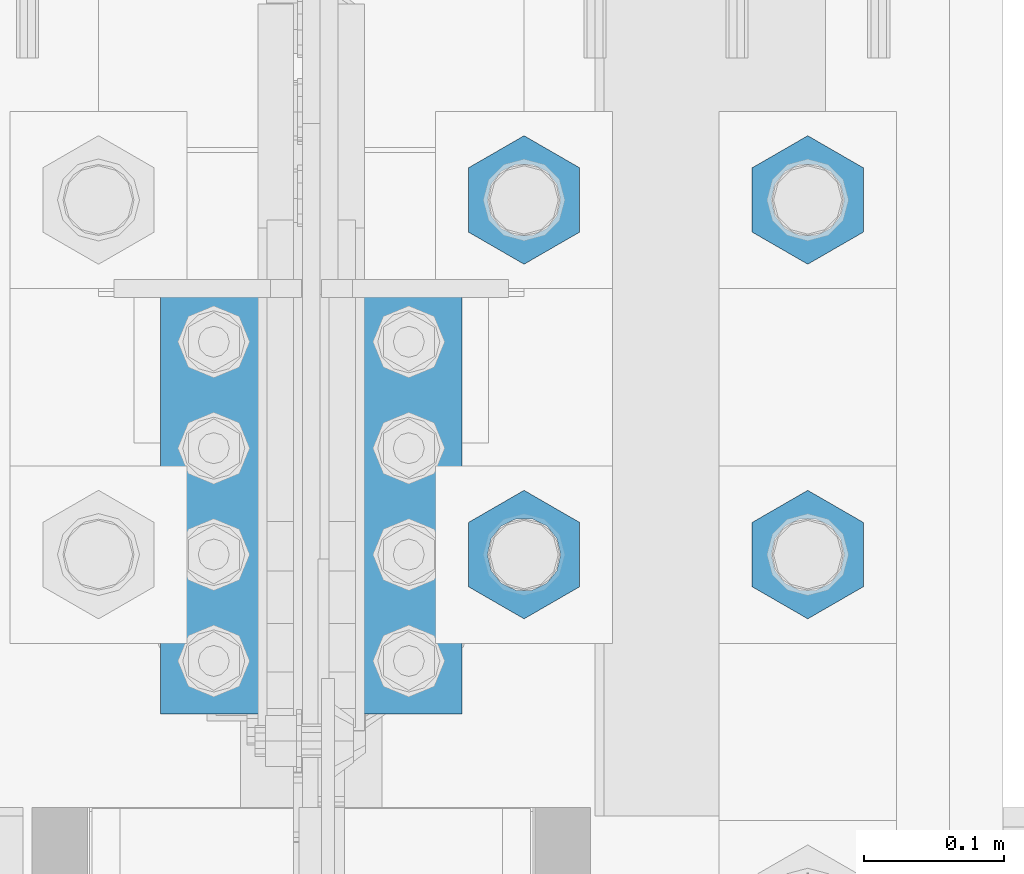
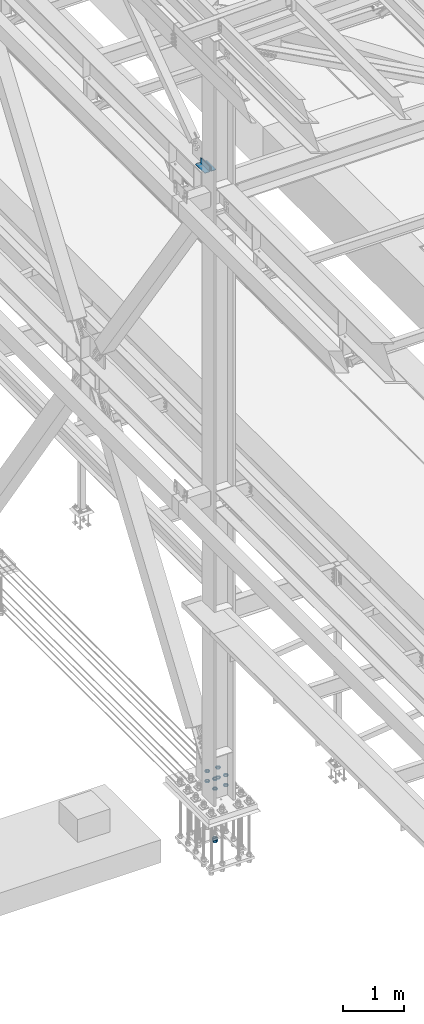
# One storey, part 2199 of 3843: 12 beams, 3 elements without a shape of their own.
"""IFC2X3 building model written with IfcOpenShell, lengths in millimetres."""

import ifcopenshell
import ifcopenshell.guid

model = None  # the IFC model being written
_history = None  # IfcOwnerHistory: only IFC2X3 demands one
_inside = {}  # id of a spatial element -> (the spatial element, [elements in it])
_under = {}  # id of a project, library or spatial element -> (it, [spatial elements below it])
_declared = {}  # id of a project -> (the project, [libraries it declares])
_typed = {}  # id of a type object -> (the type object, [elements of that type])
_made_of = {}  # id of a material, layer set ... -> (it, [elements and type objects made of it])


def new_model(schema):
    """Start an empty IFC model of exactly this schema.

    Asked for "IFC4X3", IfcOpenShell would pick the latest addendum, in which some entities
    have other attributes; the version numbers below select the first issue.
    IFC2X3 requires an IfcOwnerHistory on every rooted entity: one is made here for all.
    """
    global model, _history
    if schema == "IFC4X3":
        model = ifcopenshell.file(schema_version=(4, 3, 0, 0))
    else:
        model = ifcopenshell.file(schema=schema)
    _inside.clear()
    _under.clear()
    _declared.clear()
    _typed.clear()
    _made_of.clear()
    _history = None
    if model.schema == "IFC2X3":
        org = make("IfcOrganization", Name="unknown")
        user = make(
            "IfcPersonAndOrganization",
            ThePerson=make("IfcPerson", FamilyName="unknown"),
            TheOrganization=org,
        )
        app = make(
            "IfcApplication",
            ApplicationDeveloper=org,
            Version="unknown",
            ApplicationFullName="unknown",
            ApplicationIdentifier="unknown",
        )
        _history = make(
            "IfcOwnerHistory",
            OwningUser=user,
            OwningApplication=app,
            ChangeAction="ADDED",
            CreationDate=0,
        )
    return model


def make(cls, **values):
    """One entity of the class cls with the attributes given. An attribute that is None is left unset."""
    return model.create_entity(
        cls, **{name: value for name, value in values.items() if value is not None}
    )


def rooted(cls, **values):
    """An entity with a GlobalId (a new one), such as an element, a storey or a relation."""
    return make(cls, GlobalId=ifcopenshell.guid.new(), OwnerHistory=_history, **values)


def si_unit(unit_type, name, prefix=None):
    """IfcSIUnit, for example si_unit("LENGTHUNIT", "METRE", prefix="MILLI")."""
    return make("IfcSIUnit", UnitType=unit_type, Prefix=prefix, Name=name)


def assignment(units):
    """IfcUnitAssignment: the units of a project."""
    return None if units is None else make("IfcUnitAssignment", Units=units)


def point(xyz):
    """IfcCartesianPoint."""
    return None if xyz is None else make("IfcCartesianPoint", Coordinates=xyz)


def direction(xyz):
    """IfcDirection."""
    return None if xyz is None else make("IfcDirection", DirectionRatios=xyz)


def frame(location, z_axis=None, x_axis=None):
    """IfcAxis2Placement3D, a coordinate frame: its origin and axes. An axis left out is left unset."""
    return make(
        "IfcAxis2Placement3D",
        Location=point(location),
        Axis=direction(z_axis),
        RefDirection=direction(x_axis),
    )


def origin_with_axes():
    """The frame at (0, 0, 0) with the z axis (0, 0, 1) and the x axis (1, 0, 0) written out."""
    return frame((0.0, 0.0, 0.0), z_axis=(0.0, 0.0, 1.0), x_axis=(1.0, 0.0, 0.0))


def place(relative_to, where):
    """IfcLocalPlacement: puts the frame where relative to a parent placement (None: the world)."""
    return make(
        "IfcLocalPlacement", PlacementRelTo=relative_to, RelativePlacement=where
    )


def context(
    kind, dimensions, precision=None, world=None, true_north=None, identifier=None
):
    """IfcGeometricRepresentationContext, for example the 3D "Model" context."""
    return make(
        "IfcGeometricRepresentationContext",
        ContextIdentifier=identifier,
        ContextType=kind,
        CoordinateSpaceDimension=dimensions,
        Precision=precision,
        WorldCoordinateSystem=world,
        TrueNorth=true_north,
    )


def subcontext(parent, identifier, kind, view, scale=None):
    """IfcGeometricRepresentationSubContext, for example "Body" below "Model"."""
    return make(
        "IfcGeometricRepresentationSubContext",
        ContextIdentifier=identifier,
        ContextType=kind,
        ParentContext=parent,
        TargetScale=scale,
        TargetView=view,
    )


def project(units=None, contexts=None):
    """IfcProject with its units and contexts."""
    return rooted(
        "IfcProject",
        Name="project",
        RepresentationContexts=contexts,
        UnitsInContext=assignment(units),
    )


def spatial(cls, under=None, at=None, **own):
    """A site, building, storey or space (cls), placed at a placement, below another one or the project."""
    s = rooted(cls, ObjectPlacement=at, **own)
    if under is not None:
        _under.setdefault(under.id(), (under, []))[1].append(s)
    return s


def faces_of(points, faces, orient=None, outer=None):
    """IfcFace entities. A face is a list of loops; a loop is a list of indices into points, from 0.

    orient and outer hold one flag for each loop. By default every Orientation is true, the
    first loop of a face is its IfcFaceOuterBound and the others are IfcFaceBound.
    """
    made = []
    for i, loops in enumerate(faces):
        bounds = []
        for j, loop in enumerate(loops):
            is_outer = j == 0 if outer is None else outer[i][j]
            bounds.append(
                make(
                    "IfcFaceOuterBound" if is_outer else "IfcFaceBound",
                    Bound=make("IfcPolyLoop", Polygon=[points[k] for k in loop]),
                    Orientation=True if orient is None else orient[i][j],
                )
            )
        made.append(make("IfcFace", Bounds=bounds))
    return made


def faceted_brep(points, faces, orient=None, outer=None, voids=None):
    """IfcFacetedBrep: a solid bounded by flat faces; with voids (closed shells), ...WithVoids."""
    shared = [point(p) for p in points]
    hull = make("IfcClosedShell", CfsFaces=faces_of(shared, faces, orient, outer))
    if voids is None:
        return make("IfcFacetedBrep", Outer=hull)
    return make(
        "IfcFacetedBrepWithVoids",
        Outer=hull,
        Voids=[
            make(cls, CfsFaces=faces_of(shared, fs, o, b)) for cls, fs, o, b in voids
        ],
    )


def shape(context_of_items, identifier, shape_type, items):
    """IfcShapeRepresentation: the items that make up one representation, for example the "Body"."""
    return make(
        "IfcShapeRepresentation",
        ContextOfItems=context_of_items,
        RepresentationIdentifier=identifier,
        RepresentationType=shape_type,
        Items=items,
    )


def material(Name=None, Category=None):
    """IfcMaterial."""
    return make("IfcMaterial", Name=Name, Category=Category)


def made_of(thing, what):
    """Note that an element or type object is made of a material, layer set ...; save() writes the relation."""
    if what is not None:
        _made_of.setdefault(what.id(), (what, []))[1].append(thing)
    return thing


def type_object(cls, material=None, **own):
    """A type object (cls), such as IfcWallType, which elements share."""
    return made_of(rooted(cls, **own), material)


def element(
    cls,
    number,
    at=None,
    inside=None,
    cuts=None,
    type_object=None,
    material=None,
    context=None,
    identifier="Body",
    shape_type=None,
    held_by="IfcProductDefinitionShape",
    body=None,
    shapes=None,
    **own,
):
    """One element of the class cls, such as IfcWall. Its Tag is "e" and its number.

    at: its placement. inside: the storey or other place that contains it. cuts: it is an
    opening in that element (IfcRelVoidsElement). A single representation is given by context,
    identifier, shape_type and body (its items); several are given by shapes. held_by: the class
    of the entity that holds the representations. save() writes the other relations.
    """
    e = rooted(cls, Tag="e%d" % number, ObjectPlacement=at, **own)
    if body is not None:
        shapes = [shape(context, identifier, shape_type, body)]
    if shapes is not None:
        e.Representation = make(held_by, Representations=shapes)
    if inside is not None:
        _inside.setdefault(inside.id(), (inside, []))[1].append(e)
    if cuts is not None:
        rooted(
            "IfcRelVoidsElement", RelatingBuildingElement=cuts, RelatedOpeningElement=e
        )
    if type_object is not None:
        _typed.setdefault(type_object.id(), (type_object, []))[1].append(e)
    return made_of(e, material)


def aggregate(whole, parts):
    """IfcRelAggregates: a whole, such as a stair, and the parts it consists of."""
    return rooted("IfcRelAggregates", RelatingObject=whole, RelatedObjects=parts)


def save(model, path):
    """Write the relations noted so far, then the file.

    IfcRelAggregates (storeys below a building ...), IfcRelContainedInSpatialStructure (elements
    in a storey), IfcRelDefinesByType, IfcRelAssociatesMaterial and IfcRelDeclares: one each for
    every whole, place, type object, material and project.
    """
    for whole, parts in _under.values():
        aggregate(whole, parts)
    for where, things in _inside.values():
        rooted(
            "IfcRelContainedInSpatialStructure",
            RelatedElements=things,
            RelatingStructure=where,
        )
    for kind, things in _typed.values():
        rooted("IfcRelDefinesByType", RelatedObjects=things, RelatingType=kind)
    for what, things in _made_of.values():
        rooted("IfcRelAssociatesMaterial", RelatedObjects=things, RelatingMaterial=what)
    for by, libraries in _declared.values():
        rooted("IfcRelDeclares", RelatingContext=by, RelatedDefinitions=libraries)
    model.write(path)


model = new_model("IFC2X3")

# Units and contexts
model_context = context("Model", 3, precision=1e-05, world=origin_with_axes())
body_context = subcontext(model_context, "Body", "Model", "MODEL_VIEW")
ifc_project = project(units=[si_unit("LENGTHUNIT", "METRE", prefix="MILLI"), si_unit("AREAUNIT", "SQUARE_METRE"), si_unit("VOLUMEUNIT", "CUBIC_METRE"), si_unit("MASSUNIT", "GRAM", prefix="KILO"), si_unit("TIMEUNIT", "SECOND"), si_unit("PLANEANGLEUNIT", "RADIAN"), si_unit("SOLIDANGLEUNIT", "STERADIAN"), si_unit("THERMODYNAMICTEMPERATUREUNIT", "DEGREE_CELSIUS"), si_unit("LUMINOUSINTENSITYUNIT", "LUMEN")], contexts=[model_context])

# Site, building, storey
site_placement = place(None, origin_with_axes())
site = spatial("IfcSite", under=ifc_project, at=site_placement, CompositionType="ELEMENT")
building_placement = place(site_placement, origin_with_axes())
building = spatial("IfcBuilding", under=site, at=building_placement, Name="Undefined", CompositionType="ELEMENT")
storey_placement = place(building_placement, origin_with_axes())
storey = spatial("IfcBuildingStorey", under=building, at=storey_placement, Name="Undefined", CompositionType="ELEMENT", Elevation=0.0)

# Assembly, beams
assembly_1_placement = place(storey_placement, origin_with_axes())
assembly_1 = element("IfcElementAssembly", 1, at=assembly_1_placement, inside=storey, Name="TEMPLATE", AssemblyPlace="NOTDEFINED", PredefinedType="RIGID_FRAME")
ifc_material = material(Name="STEEL/A572-50")
beam_type_1 = type_object("IfcBeamType", Name="2_HALF_NUT", PredefinedType="NOTDEFINED")
beam_1_placement = place(assembly_1_placement, frame((36931.6, 50939.7, 30060.9), z_axis=(1.0, 0.0, 0.0), x_axis=(0.0, 0.0, -1.0)))
beam_1 = element("IfcBeam", 2, at=beam_1_placement, type_object=beam_type_1, material=ifc_material, Name="NUT", ObjectType="2_HALF_NUT", context=body_context, shape_type="Brep", body=[
    faceted_brep([(0.0, -46.0369987487793, 0.0), (0.0, -23.0184993743896, -39.869213104248), (25.4000000000015, -23.0184993743896, -39.869213104248), (25.4000000000015, -46.0369987487793, 0.0), (0.0, 23.0184993743896, -39.869213104248), (25.4000000000015, 23.0184993743896, -39.869213104248), (0.0, 46.0369987487793, 0.0), (25.4000000000015, 46.0369987487793, 0.0), (0.0, 23.0184993743896, 39.869213104248), (25.4000000000015, 23.0184993743896, 39.869213104248), (0.0, -23.0184993743896, 39.869213104248), (25.4000000000015, -23.0184993743896, 39.869213104248), (0.0, 0.0, 26.1940002441406), (0.0, 11.3650617044477, 23.5999013092805), (25.4000000000015, 11.3650617044477, 23.5999013092805), (25.4000000000015, 0.0, 26.1940002441406), (0.0, 20.4791109456419, 16.3316083006721), (25.4000000000015, 20.4791109456419, 16.3316083006721), (0.0, 25.5370200498292, 5.82867859874386), (25.4000000000015, 25.5370200498292, 5.82867859874386), (0.0, 25.5370200498292, -5.82867859874386), (25.4000000000015, 25.5370200498292, -5.82867859874386), (0.0, 20.4791109456419, -16.3316083006721), (25.4000000000015, 20.4791109456419, -16.3316083006721), (0.0, 11.3650617044477, -23.5999013092805), (25.4000000000015, 11.3650617044477, -23.5999013092805), (0.0, 0.0, -26.1940002441406), (25.4000000000015, 0.0, -26.1940002441406), (0.0, -11.3650617044477, -23.5999013092805), (25.4000000000015, -11.3650617044477, -23.5999013092805), (0.0, -20.4791109456419, -16.3316083006721), (25.4000000000015, -20.4791109456419, -16.3316083006721), (0.0, -25.5370200498292, -5.82867859874386), (25.4000000000015, -25.5370200498292, -5.82867859874386), (0.0, -25.5370200498292, 5.82867859874386), (25.4000000000015, -25.5370200498292, 5.82867859874386), (0.0, -20.4791109456419, 16.3316083006721), (25.4000000000015, -20.4791109456419, 16.3316083006721), (0.0, -11.3650617044477, 23.5999013092805), (25.4000000000015, -11.3650617044477, 23.5999013092805)], [[[0, 1, 2, 3]], [[1, 4, 5, 2]], [[4, 6, 7, 5]], [[6, 8, 9, 7]], [[8, 10, 11, 9]], [[10, 0, 3, 11]], [[12, 13, 14, 15]], [[13, 16, 17, 14]], [[16, 18, 19, 17]], [[18, 20, 21, 19]], [[20, 22, 23, 21]], [[22, 24, 25, 23]], [[24, 26, 27, 25]], [[26, 28, 29, 27]], [[28, 30, 31, 29]], [[30, 32, 33, 31]], [[32, 34, 35, 33]], [[34, 36, 37, 35]], [[36, 38, 39, 37]], [[38, 12, 15, 39]], [[5, 7, 9, 11, 3, 2], [17, 19, 21, 23, 25, 27, 29, 31, 33, 35, 37, 39, 15, 14]], [[10, 8, 6, 4, 1, 0], [38, 36, 34, 32, 30, 28, 26, 24, 22, 20, 18, 16, 13, 12]]]),
])
beam_2_placement = place(assembly_1_placement, frame((36728.4, 50939.7, 30060.9), z_axis=(1.0, 0.0, 0.0), x_axis=(0.0, 0.0, -1.0)))
beam_2 = element("IfcBeam", 3, at=beam_2_placement, type_object=beam_type_1, material=ifc_material, Name="NUT", ObjectType="2_HALF_NUT", context=body_context, shape_type="Brep", body=[
    faceted_brep([(0.0, -46.0369987487793, 0.0), (0.0, -23.0184993743896, -39.869213104248), (25.4000000000015, -23.0184993743896, -39.869213104248), (25.4000000000015, -46.0369987487793, 0.0), (0.0, 23.0184993743896, -39.869213104248), (25.4000000000015, 23.0184993743896, -39.869213104248), (0.0, 46.0369987487793, 0.0), (25.4000000000015, 46.0369987487793, 0.0), (0.0, 23.0184993743896, 39.869213104248), (25.4000000000015, 23.0184993743896, 39.869213104248), (0.0, -23.0184993743896, 39.869213104248), (25.4000000000015, -23.0184993743896, 39.869213104248), (0.0, 0.0, 26.1940002441406), (0.0, 11.3650617044477, 23.5999013092805), (25.4000000000015, 11.3650617044477, 23.5999013092805), (25.4000000000015, 0.0, 26.1940002441406), (0.0, 20.4791109456419, 16.3316083006721), (25.4000000000015, 20.4791109456419, 16.3316083006721), (0.0, 25.5370200498292, 5.82867859874386), (25.4000000000015, 25.5370200498292, 5.82867859874386), (0.0, 25.5370200498292, -5.82867859874386), (25.4000000000015, 25.5370200498292, -5.82867859874386), (0.0, 20.4791109456419, -16.3316083006721), (25.4000000000015, 20.4791109456419, -16.3316083006721), (0.0, 11.3650617044477, -23.5999013092805), (25.4000000000015, 11.3650617044477, -23.5999013092805), (0.0, 0.0, -26.1940002441406), (25.4000000000015, 0.0, -26.1940002441406), (0.0, -11.3650617044477, -23.5999013092805), (25.4000000000015, -11.3650617044477, -23.5999013092805), (0.0, -20.4791109456419, -16.3316083006721), (25.4000000000015, -20.4791109456419, -16.3316083006721), (0.0, -25.5370200498292, -5.82867859874386), (25.4000000000015, -25.5370200498292, -5.82867859874386), (0.0, -25.5370200498292, 5.82867859874386), (25.4000000000015, -25.5370200498292, 5.82867859874386), (0.0, -20.4791109456419, 16.3316083006721), (25.4000000000015, -20.4791109456419, 16.3316083006721), (0.0, -11.3650617044477, 23.5999013092805), (25.4000000000015, -11.3650617044477, 23.5999013092805)], [[[0, 1, 2, 3]], [[1, 4, 5, 2]], [[4, 6, 7, 5]], [[6, 8, 9, 7]], [[8, 10, 11, 9]], [[10, 0, 3, 11]], [[12, 13, 14, 15]], [[13, 16, 17, 14]], [[16, 18, 19, 17]], [[18, 20, 21, 19]], [[20, 22, 23, 21]], [[22, 24, 25, 23]], [[24, 26, 27, 25]], [[26, 28, 29, 27]], [[28, 30, 31, 29]], [[30, 32, 33, 31]], [[32, 34, 35, 33]], [[34, 36, 37, 35]], [[36, 38, 39, 37]], [[38, 12, 15, 39]], [[5, 7, 9, 11, 3, 2], [17, 19, 21, 23, 25, 27, 29, 31, 33, 35, 37, 39, 15, 14]], [[10, 8, 6, 4, 1, 0], [38, 36, 34, 32, 30, 28, 26, 24, 22, 20, 18, 16, 13, 12]]]),
])
beam_3_placement = place(assembly_1_placement, frame((36931.6, 51193.7, 30060.9), z_axis=(1.0, 0.0, 0.0), x_axis=(0.0, 0.0, -1.0)))
beam_3 = element("IfcBeam", 4, at=beam_3_placement, type_object=beam_type_1, material=ifc_material, Name="NUT", ObjectType="2_HALF_NUT", context=body_context, shape_type="Brep", body=[
    faceted_brep([(0.0, -46.0369987487793, 0.0), (0.0, -23.0184993743896, -39.869213104248), (25.4000000000015, -23.0184993743896, -39.869213104248), (25.4000000000015, -46.0369987487793, 0.0), (0.0, 23.0184993743896, -39.869213104248), (25.4000000000015, 23.0184993743896, -39.869213104248), (0.0, 46.0369987487793, 0.0), (25.4000000000015, 46.0369987487793, 0.0), (0.0, 23.0184993743896, 39.869213104248), (25.4000000000015, 23.0184993743896, 39.869213104248), (0.0, -23.0184993743896, 39.869213104248), (25.4000000000015, -23.0184993743896, 39.869213104248), (0.0, 0.0, 26.1940002441406), (0.0, 11.3650617044477, 23.5999013092805), (25.4000000000015, 11.3650617044477, 23.5999013092805), (25.4000000000015, 0.0, 26.1940002441406), (0.0, 20.4791109456419, 16.3316083006721), (25.4000000000015, 20.4791109456419, 16.3316083006721), (0.0, 25.5370200498292, 5.82867859874386), (25.4000000000015, 25.5370200498292, 5.82867859874386), (0.0, 25.5370200498292, -5.82867859874386), (25.4000000000015, 25.5370200498292, -5.82867859874386), (0.0, 20.4791109456419, -16.3316083006721), (25.4000000000015, 20.4791109456419, -16.3316083006721), (0.0, 11.3650617044477, -23.5999013092805), (25.4000000000015, 11.3650617044477, -23.5999013092805), (0.0, 0.0, -26.1940002441406), (25.4000000000015, 0.0, -26.1940002441406), (0.0, -11.3650617044477, -23.5999013092805), (25.4000000000015, -11.3650617044477, -23.5999013092805), (0.0, -20.4791109456419, -16.3316083006721), (25.4000000000015, -20.4791109456419, -16.3316083006721), (0.0, -25.5370200498292, -5.82867859874386), (25.4000000000015, -25.5370200498292, -5.82867859874386), (0.0, -25.5370200498292, 5.82867859874386), (25.4000000000015, -25.5370200498292, 5.82867859874386), (0.0, -20.4791109456419, 16.3316083006721), (25.4000000000015, -20.4791109456419, 16.3316083006721), (0.0, -11.3650617044477, 23.5999013092805), (25.4000000000015, -11.3650617044477, 23.5999013092805)], [[[0, 1, 2, 3]], [[1, 4, 5, 2]], [[4, 6, 7, 5]], [[6, 8, 9, 7]], [[8, 10, 11, 9]], [[10, 0, 3, 11]], [[12, 13, 14, 15]], [[13, 16, 17, 14]], [[16, 18, 19, 17]], [[18, 20, 21, 19]], [[20, 22, 23, 21]], [[22, 24, 25, 23]], [[24, 26, 27, 25]], [[26, 28, 29, 27]], [[28, 30, 31, 29]], [[30, 32, 33, 31]], [[32, 34, 35, 33]], [[34, 36, 37, 35]], [[36, 38, 39, 37]], [[38, 12, 15, 39]], [[5, 7, 9, 11, 3, 2], [17, 19, 21, 23, 25, 27, 29, 31, 33, 35, 37, 39, 15, 14]], [[10, 8, 6, 4, 1, 0], [38, 36, 34, 32, 30, 28, 26, 24, 22, 20, 18, 16, 13, 12]]]),
])
beam_4_placement = place(assembly_1_placement, frame((36728.4, 51193.7, 30060.9), z_axis=(1.0, 0.0, 0.0), x_axis=(0.0, 0.0, -1.0)))
beam_4 = element("IfcBeam", 5, at=beam_4_placement, type_object=beam_type_1, material=ifc_material, Name="NUT", ObjectType="2_HALF_NUT", context=body_context, shape_type="Brep", body=[
    faceted_brep([(0.0, -46.0369987487793, 0.0), (0.0, -23.0184993743896, -39.869213104248), (25.4000000000015, -23.0184993743896, -39.869213104248), (25.4000000000015, -46.0369987487793, 0.0), (0.0, 23.0184993743896, -39.869213104248), (25.4000000000015, 23.0184993743896, -39.869213104248), (0.0, 46.0369987487793, 0.0), (25.4000000000015, 46.0369987487793, 0.0), (0.0, 23.0184993743896, 39.869213104248), (25.4000000000015, 23.0184993743896, 39.869213104248), (0.0, -23.0184993743896, 39.869213104248), (25.4000000000015, -23.0184993743896, 39.869213104248), (0.0, 0.0, 26.1940002441406), (0.0, 11.3650617044477, 23.5999013092805), (25.4000000000015, 11.3650617044477, 23.5999013092805), (25.4000000000015, 0.0, 26.1940002441406), (0.0, 20.4791109456419, 16.3316083006721), (25.4000000000015, 20.4791109456419, 16.3316083006721), (0.0, 25.5370200498292, 5.82867859874386), (25.4000000000015, 25.5370200498292, 5.82867859874386), (0.0, 25.5370200498292, -5.82867859874386), (25.4000000000015, 25.5370200498292, -5.82867859874386), (0.0, 20.4791109456419, -16.3316083006721), (25.4000000000015, 20.4791109456419, -16.3316083006721), (0.0, 11.3650617044477, -23.5999013092805), (25.4000000000015, 11.3650617044477, -23.5999013092805), (0.0, 0.0, -26.1940002441406), (25.4000000000015, 0.0, -26.1940002441406), (0.0, -11.3650617044477, -23.5999013092805), (25.4000000000015, -11.3650617044477, -23.5999013092805), (0.0, -20.4791109456419, -16.3316083006721), (25.4000000000015, -20.4791109456419, -16.3316083006721), (0.0, -25.5370200498292, -5.82867859874386), (25.4000000000015, -25.5370200498292, -5.82867859874386), (0.0, -25.5370200498292, 5.82867859874386), (25.4000000000015, -25.5370200498292, 5.82867859874386), (0.0, -20.4791109456419, 16.3316083006721), (25.4000000000015, -20.4791109456419, 16.3316083006721), (0.0, -11.3650617044477, 23.5999013092805), (25.4000000000015, -11.3650617044477, 23.5999013092805)], [[[0, 1, 2, 3]], [[1, 4, 5, 2]], [[4, 6, 7, 5]], [[6, 8, 9, 7]], [[8, 10, 11, 9]], [[10, 0, 3, 11]], [[12, 13, 14, 15]], [[13, 16, 17, 14]], [[16, 18, 19, 17]], [[18, 20, 21, 19]], [[20, 22, 23, 21]], [[22, 24, 25, 23]], [[24, 26, 27, 25]], [[26, 28, 29, 27]], [[28, 30, 31, 29]], [[30, 32, 33, 31]], [[32, 34, 35, 33]], [[34, 36, 37, 35]], [[36, 38, 39, 37]], [[38, 12, 15, 39]], [[5, 7, 9, 11, 3, 2], [17, 19, 21, 23, 25, 27, 29, 31, 33, 35, 37, 39, 15, 14]], [[10, 8, 6, 4, 1, 0], [38, 36, 34, 32, 30, 28, 26, 24, 22, 20, 18, 16, 13, 12]]]),
])
beam_5_placement = place(assembly_1_placement, frame((36728.4, 50939.7, 30257.75), z_axis=(-1.0, 0.0, 0.0), x_axis=(0.0, 0.0, -1.0)))
beam_5 = element("IfcBeam", 6, at=beam_5_placement, type_object=beam_type_1, material=ifc_material, Name="NUT", ObjectType="2_HALF_NUT", context=body_context, shape_type="Brep", body=[
    faceted_brep([(0.0, -46.0369987487793, 0.0), (0.0, -23.0184993743896, -39.869213104248), (25.4000000000015, -23.0184993743896, -39.869213104248), (25.4000000000015, -46.0369987487793, 0.0), (0.0, 23.0184993743896, -39.869213104248), (25.4000000000015, 23.0184993743896, -39.869213104248), (0.0, 46.0369987487793, 0.0), (25.4000000000015, 46.0369987487793, 0.0), (0.0, 23.0184993743896, 39.869213104248), (25.4000000000015, 23.0184993743896, 39.869213104248), (0.0, -23.0184993743896, 39.869213104248), (25.4000000000015, -23.0184993743896, 39.869213104248), (0.0, 0.0, 26.1940002441406), (0.0, 11.3650617044477, 23.5999013092805), (25.4000000000015, 11.3650617044477, 23.5999013092805), (25.4000000000015, 0.0, 26.1940002441406), (0.0, 20.4791109456419, 16.3316083006721), (25.4000000000015, 20.4791109456419, 16.3316083006721), (0.0, 25.5370200498292, 5.82867859874386), (25.4000000000015, 25.5370200498292, 5.82867859874386), (0.0, 25.5370200498292, -5.82867859874386), (25.4000000000015, 25.5370200498292, -5.82867859874386), (0.0, 20.4791109456419, -16.3316083006721), (25.4000000000015, 20.4791109456419, -16.3316083006721), (0.0, 11.3650617044477, -23.5999013092805), (25.4000000000015, 11.3650617044477, -23.5999013092805), (0.0, 0.0, -26.1940002441406), (25.4000000000015, 0.0, -26.1940002441406), (0.0, -11.3650617044477, -23.5999013092805), (25.4000000000015, -11.3650617044477, -23.5999013092805), (0.0, -20.4791109456419, -16.3316083006721), (25.4000000000015, -20.4791109456419, -16.3316083006721), (0.0, -25.5370200498292, -5.82867859874386), (25.4000000000015, -25.5370200498292, -5.82867859874386), (0.0, -25.5370200498292, 5.82867859874386), (25.4000000000015, -25.5370200498292, 5.82867859874386), (0.0, -20.4791109456419, 16.3316083006721), (25.4000000000015, -20.4791109456419, 16.3316083006721), (0.0, -11.3650617044477, 23.5999013092805), (25.4000000000015, -11.3650617044477, 23.5999013092805)], [[[0, 1, 2, 3]], [[1, 4, 5, 2]], [[4, 6, 7, 5]], [[6, 8, 9, 7]], [[8, 10, 11, 9]], [[10, 0, 3, 11]], [[12, 13, 14, 15]], [[13, 16, 17, 14]], [[16, 18, 19, 17]], [[18, 20, 21, 19]], [[20, 22, 23, 21]], [[22, 24, 25, 23]], [[24, 26, 27, 25]], [[26, 28, 29, 27]], [[28, 30, 31, 29]], [[30, 32, 33, 31]], [[32, 34, 35, 33]], [[34, 36, 37, 35]], [[36, 38, 39, 37]], [[38, 12, 15, 39]], [[5, 7, 9, 11, 3, 2], [17, 19, 21, 23, 25, 27, 29, 31, 33, 35, 37, 39, 15, 14]], [[10, 8, 6, 4, 1, 0], [38, 36, 34, 32, 30, 28, 26, 24, 22, 20, 18, 16, 13, 12]]]),
])
beam_6_placement = place(assembly_1_placement, frame((36931.6, 50939.7, 30257.75), z_axis=(-1.0, 0.0, 0.0), x_axis=(0.0, 0.0, -1.0)))
beam_6 = element("IfcBeam", 7, at=beam_6_placement, type_object=beam_type_1, material=ifc_material, Name="NUT", ObjectType="2_HALF_NUT", context=body_context, shape_type="Brep", body=[
    faceted_brep([(0.0, -46.0369987487793, 0.0), (0.0, -23.0184993743896, -39.869213104248), (25.4000000000015, -23.0184993743896, -39.869213104248), (25.4000000000015, -46.0369987487793, 0.0), (0.0, 23.0184993743896, -39.869213104248), (25.4000000000015, 23.0184993743896, -39.869213104248), (0.0, 46.0369987487793, 0.0), (25.4000000000015, 46.0369987487793, 0.0), (0.0, 23.0184993743896, 39.869213104248), (25.4000000000015, 23.0184993743896, 39.869213104248), (0.0, -23.0184993743896, 39.869213104248), (25.4000000000015, -23.0184993743896, 39.869213104248), (0.0, 0.0, 26.1940002441406), (0.0, 11.3650617044477, 23.5999013092805), (25.4000000000015, 11.3650617044477, 23.5999013092805), (25.4000000000015, 0.0, 26.1940002441406), (0.0, 20.4791109456419, 16.3316083006721), (25.4000000000015, 20.4791109456419, 16.3316083006721), (0.0, 25.5370200498292, 5.82867859874386), (25.4000000000015, 25.5370200498292, 5.82867859874386), (0.0, 25.5370200498292, -5.82867859874386), (25.4000000000015, 25.5370200498292, -5.82867859874386), (0.0, 20.4791109456419, -16.3316083006721), (25.4000000000015, 20.4791109456419, -16.3316083006721), (0.0, 11.3650617044477, -23.5999013092805), (25.4000000000015, 11.3650617044477, -23.5999013092805), (0.0, 0.0, -26.1940002441406), (25.4000000000015, 0.0, -26.1940002441406), (0.0, -11.3650617044477, -23.5999013092805), (25.4000000000015, -11.3650617044477, -23.5999013092805), (0.0, -20.4791109456419, -16.3316083006721), (25.4000000000015, -20.4791109456419, -16.3316083006721), (0.0, -25.5370200498292, -5.82867859874386), (25.4000000000015, -25.5370200498292, -5.82867859874386), (0.0, -25.5370200498292, 5.82867859874386), (25.4000000000015, -25.5370200498292, 5.82867859874386), (0.0, -20.4791109456419, 16.3316083006721), (25.4000000000015, -20.4791109456419, 16.3316083006721), (0.0, -11.3650617044477, 23.5999013092805), (25.4000000000015, -11.3650617044477, 23.5999013092805)], [[[0, 1, 2, 3]], [[1, 4, 5, 2]], [[4, 6, 7, 5]], [[6, 8, 9, 7]], [[8, 10, 11, 9]], [[10, 0, 3, 11]], [[12, 13, 14, 15]], [[13, 16, 17, 14]], [[16, 18, 19, 17]], [[18, 20, 21, 19]], [[20, 22, 23, 21]], [[22, 24, 25, 23]], [[24, 26, 27, 25]], [[26, 28, 29, 27]], [[28, 30, 31, 29]], [[30, 32, 33, 31]], [[32, 34, 35, 33]], [[34, 36, 37, 35]], [[36, 38, 39, 37]], [[38, 12, 15, 39]], [[5, 7, 9, 11, 3, 2], [17, 19, 21, 23, 25, 27, 29, 31, 33, 35, 37, 39, 15, 14]], [[10, 8, 6, 4, 1, 0], [38, 36, 34, 32, 30, 28, 26, 24, 22, 20, 18, 16, 13, 12]]]),
])
beam_7_placement = place(assembly_1_placement, frame((36931.6, 51193.7, 30257.75), z_axis=(-1.0, 0.0, 0.0), x_axis=(0.0, 0.0, -1.0)))
beam_7 = element("IfcBeam", 8, at=beam_7_placement, type_object=beam_type_1, material=ifc_material, Name="NUT", ObjectType="2_HALF_NUT", context=body_context, shape_type="Brep", body=[
    faceted_brep([(0.0, -46.0369987487793, 0.0), (0.0, -23.0184993743896, -39.869213104248), (25.4000000000015, -23.0184993743896, -39.869213104248), (25.4000000000015, -46.0369987487793, 0.0), (0.0, 23.0184993743896, -39.869213104248), (25.4000000000015, 23.0184993743896, -39.869213104248), (0.0, 46.0369987487793, 0.0), (25.4000000000015, 46.0369987487793, 0.0), (0.0, 23.0184993743896, 39.869213104248), (25.4000000000015, 23.0184993743896, 39.869213104248), (0.0, -23.0184993743896, 39.869213104248), (25.4000000000015, -23.0184993743896, 39.869213104248), (0.0, 0.0, 26.1940002441406), (0.0, 11.3650617044477, 23.5999013092805), (25.4000000000015, 11.3650617044477, 23.5999013092805), (25.4000000000015, 0.0, 26.1940002441406), (0.0, 20.4791109456419, 16.3316083006721), (25.4000000000015, 20.4791109456419, 16.3316083006721), (0.0, 25.5370200498292, 5.82867859874386), (25.4000000000015, 25.5370200498292, 5.82867859874386), (0.0, 25.5370200498292, -5.82867859874386), (25.4000000000015, 25.5370200498292, -5.82867859874386), (0.0, 20.4791109456419, -16.3316083006721), (25.4000000000015, 20.4791109456419, -16.3316083006721), (0.0, 11.3650617044477, -23.5999013092805), (25.4000000000015, 11.3650617044477, -23.5999013092805), (0.0, 0.0, -26.1940002441406), (25.4000000000015, 0.0, -26.1940002441406), (0.0, -11.3650617044477, -23.5999013092805), (25.4000000000015, -11.3650617044477, -23.5999013092805), (0.0, -20.4791109456419, -16.3316083006721), (25.4000000000015, -20.4791109456419, -16.3316083006721), (0.0, -25.5370200498292, -5.82867859874386), (25.4000000000015, -25.5370200498292, -5.82867859874386), (0.0, -25.5370200498292, 5.82867859874386), (25.4000000000015, -25.5370200498292, 5.82867859874386), (0.0, -20.4791109456419, 16.3316083006721), (25.4000000000015, -20.4791109456419, 16.3316083006721), (0.0, -11.3650617044477, 23.5999013092805), (25.4000000000015, -11.3650617044477, 23.5999013092805)], [[[0, 1, 2, 3]], [[1, 4, 5, 2]], [[4, 6, 7, 5]], [[6, 8, 9, 7]], [[8, 10, 11, 9]], [[10, 0, 3, 11]], [[12, 13, 14, 15]], [[13, 16, 17, 14]], [[16, 18, 19, 17]], [[18, 20, 21, 19]], [[20, 22, 23, 21]], [[22, 24, 25, 23]], [[24, 26, 27, 25]], [[26, 28, 29, 27]], [[28, 30, 31, 29]], [[30, 32, 33, 31]], [[32, 34, 35, 33]], [[34, 36, 37, 35]], [[36, 38, 39, 37]], [[38, 12, 15, 39]], [[5, 7, 9, 11, 3, 2], [17, 19, 21, 23, 25, 27, 29, 31, 33, 35, 37, 39, 15, 14]], [[10, 8, 6, 4, 1, 0], [38, 36, 34, 32, 30, 28, 26, 24, 22, 20, 18, 16, 13, 12]]]),
])
beam_8_placement = place(assembly_1_placement, frame((36728.4, 51193.7, 30257.75), z_axis=(-1.0, 0.0, 0.0), x_axis=(0.0, 0.0, -1.0)))
beam_8 = element("IfcBeam", 9, at=beam_8_placement, type_object=beam_type_1, material=ifc_material, Name="NUT", ObjectType="2_HALF_NUT", context=body_context, shape_type="Brep", body=[
    faceted_brep([(0.0, -46.0369987487793, 0.0), (0.0, -23.0184993743896, -39.869213104248), (25.4000000000015, -23.0184993743896, -39.869213104248), (25.4000000000015, -46.0369987487793, 0.0), (0.0, 23.0184993743896, -39.869213104248), (25.4000000000015, 23.0184993743896, -39.869213104248), (0.0, 46.0369987487793, 0.0), (25.4000000000015, 46.0369987487793, 0.0), (0.0, 23.0184993743896, 39.869213104248), (25.4000000000015, 23.0184993743896, 39.869213104248), (0.0, -23.0184993743896, 39.869213104248), (25.4000000000015, -23.0184993743896, 39.869213104248), (0.0, 0.0, 26.1940002441406), (0.0, 11.3650617044477, 23.5999013092805), (25.4000000000015, 11.3650617044477, 23.5999013092805), (25.4000000000015, 0.0, 26.1940002441406), (0.0, 20.4791109456419, 16.3316083006721), (25.4000000000015, 20.4791109456419, 16.3316083006721), (0.0, 25.5370200498292, 5.82867859874386), (25.4000000000015, 25.5370200498292, 5.82867859874386), (0.0, 25.5370200498292, -5.82867859874386), (25.4000000000015, 25.5370200498292, -5.82867859874386), (0.0, 20.4791109456419, -16.3316083006721), (25.4000000000015, 20.4791109456419, -16.3316083006721), (0.0, 11.3650617044477, -23.5999013092805), (25.4000000000015, 11.3650617044477, -23.5999013092805), (0.0, 0.0, -26.1940002441406), (25.4000000000015, 0.0, -26.1940002441406), (0.0, -11.3650617044477, -23.5999013092805), (25.4000000000015, -11.3650617044477, -23.5999013092805), (0.0, -20.4791109456419, -16.3316083006721), (25.4000000000015, -20.4791109456419, -16.3316083006721), (0.0, -25.5370200498292, -5.82867859874386), (25.4000000000015, -25.5370200498292, -5.82867859874386), (0.0, -25.5370200498292, 5.82867859874386), (25.4000000000015, -25.5370200498292, 5.82867859874386), (0.0, -20.4791109456419, 16.3316083006721), (25.4000000000015, -20.4791109456419, 16.3316083006721), (0.0, -11.3650617044477, 23.5999013092805), (25.4000000000015, -11.3650617044477, 23.5999013092805)], [[[0, 1, 2, 3]], [[1, 4, 5, 2]], [[4, 6, 7, 5]], [[6, 8, 9, 7]], [[8, 10, 11, 9]], [[10, 0, 3, 11]], [[12, 13, 14, 15]], [[13, 16, 17, 14]], [[16, 18, 19, 17]], [[18, 20, 21, 19]], [[20, 22, 23, 21]], [[22, 24, 25, 23]], [[24, 26, 27, 25]], [[26, 28, 29, 27]], [[28, 30, 31, 29]], [[30, 32, 33, 31]], [[32, 34, 35, 33]], [[34, 36, 37, 35]], [[36, 38, 39, 37]], [[38, 12, 15, 39]], [[5, 7, 9, 11, 3, 2], [17, 19, 21, 23, 25, 27, 29, 31, 33, 35, 37, 39, 15, 14]], [[10, 8, 6, 4, 1, 0], [38, 36, 34, 32, 30, 28, 26, 24, 22, 20, 18, 16, 13, 12]]]),
])
beam_9_placement = place(assembly_1_placement, frame((36728.4, 50939.7, 29070.3), z_axis=(-1.0, 0.0, 0.0), x_axis=(0.0, 0.0, -1.0)))
beam_9 = element("IfcBeam", 10, at=beam_9_placement, type_object=beam_type_1, material=ifc_material, Name="NUT", ObjectType="2_HALF_NUT", context=body_context, shape_type="Brep", body=[
    faceted_brep([(0.0, -46.0369987487793, 0.0), (0.0, -23.0184993743896, -39.869213104248), (25.4000000000015, -23.0184993743896, -39.869213104248), (25.4000000000015, -46.0369987487793, 0.0), (0.0, 23.0184993743896, -39.869213104248), (25.4000000000015, 23.0184993743896, -39.869213104248), (0.0, 46.0369987487793, 0.0), (25.4000000000015, 46.0369987487793, 0.0), (0.0, 23.0184993743896, 39.869213104248), (25.4000000000015, 23.0184993743896, 39.869213104248), (0.0, -23.0184993743896, 39.869213104248), (25.4000000000015, -23.0184993743896, 39.869213104248), (0.0, 0.0, 26.1940002441406), (0.0, 11.3650617044477, 23.5999013092805), (25.4000000000015, 11.3650617044477, 23.5999013092805), (25.4000000000015, 0.0, 26.1940002441406), (0.0, 20.4791109456419, 16.3316083006721), (25.4000000000015, 20.4791109456419, 16.3316083006721), (0.0, 25.5370200498292, 5.82867859874386), (25.4000000000015, 25.5370200498292, 5.82867859874386), (0.0, 25.5370200498292, -5.82867859874386), (25.4000000000015, 25.5370200498292, -5.82867859874386), (0.0, 20.4791109456419, -16.3316083006721), (25.4000000000015, 20.4791109456419, -16.3316083006721), (0.0, 11.3650617044477, -23.5999013092805), (25.4000000000015, 11.3650617044477, -23.5999013092805), (0.0, 0.0, -26.1940002441406), (25.4000000000015, 0.0, -26.1940002441406), (0.0, -11.3650617044477, -23.5999013092805), (25.4000000000015, -11.3650617044477, -23.5999013092805), (0.0, -20.4791109456419, -16.3316083006721), (25.4000000000015, -20.4791109456419, -16.3316083006721), (0.0, -25.5370200498292, -5.82867859874386), (25.4000000000015, -25.5370200498292, -5.82867859874386), (0.0, -25.5370200498292, 5.82867859874386), (25.4000000000015, -25.5370200498292, 5.82867859874386), (0.0, -20.4791109456419, 16.3316083006721), (25.4000000000015, -20.4791109456419, 16.3316083006721), (0.0, -11.3650617044477, 23.5999013092805), (25.4000000000015, -11.3650617044477, 23.5999013092805)], [[[0, 1, 2, 3]], [[1, 4, 5, 2]], [[4, 6, 7, 5]], [[6, 8, 9, 7]], [[8, 10, 11, 9]], [[10, 0, 3, 11]], [[12, 13, 14, 15]], [[13, 16, 17, 14]], [[16, 18, 19, 17]], [[18, 20, 21, 19]], [[20, 22, 23, 21]], [[22, 24, 25, 23]], [[24, 26, 27, 25]], [[26, 28, 29, 27]], [[28, 30, 31, 29]], [[30, 32, 33, 31]], [[32, 34, 35, 33]], [[34, 36, 37, 35]], [[36, 38, 39, 37]], [[38, 12, 15, 39]], [[5, 7, 9, 11, 3, 2], [17, 19, 21, 23, 25, 27, 29, 31, 33, 35, 37, 39, 15, 14]], [[10, 8, 6, 4, 1, 0], [38, 36, 34, 32, 30, 28, 26, 24, 22, 20, 18, 16, 13, 12]]]),
])
beam_type_2 = type_object("IfcBeamType", Name="2_HEAVY_HEX_NUT", PredefinedType="NOTDEFINED")
beam_10_placement = place(assembly_1_placement, frame((36728.4, 50939.7, 29044.9), z_axis=(-1.0, 0.0, 0.0), x_axis=(0.0, 0.0, -1.0)))
beam_10 = element("IfcBeam", 11, at=beam_10_placement, type_object=beam_type_2, material=ifc_material, Name="NUT", ObjectType="2_HEAVY_HEX_NUT", context=body_context, shape_type="Brep", body=[
    faceted_brep([(0.0, -46.0369987487793, 0.0), (0.0, -23.0184993743896, -39.869213104248), (50.7999999999993, -23.0184993743896, -39.869213104248), (50.7999999999993, -46.0369987487793, 0.0), (0.0, 23.0184993743896, -39.869213104248), (50.7999999999993, 23.0184993743896, -39.869213104248), (0.0, 46.0369987487793, 0.0), (50.7999999999993, 46.0369987487793, 0.0), (0.0, 23.0184993743896, 39.869213104248), (50.7999999999993, 23.0184993743896, 39.869213104248), (0.0, -23.0184993743896, 39.869213104248), (50.7999999999993, -23.0184993743896, 39.869213104248), (0.0, 0.0, 26.1940002441406), (0.0, 11.3650617044477, 23.5999013092805), (50.7999999999993, 11.3650617044477, 23.5999013092805), (50.7999999999993, 0.0, 26.1940002441406), (0.0, 20.4791109456419, 16.3316083006721), (50.7999999999993, 20.4791109456419, 16.3316083006721), (0.0, 25.5370200498292, 5.82867859874386), (50.7999999999993, 25.5370200498292, 5.82867859874386), (0.0, 25.5370200498292, -5.82867859874386), (50.7999999999993, 25.5370200498292, -5.82867859874386), (0.0, 20.4791109456419, -16.3316083006721), (50.7999999999993, 20.4791109456419, -16.3316083006721), (0.0, 11.3650617044477, -23.5999013092805), (50.7999999999993, 11.3650617044477, -23.5999013092805), (0.0, 0.0, -26.1940002441406), (50.7999999999993, 0.0, -26.1940002441406), (0.0, -11.3650617044477, -23.5999013092805), (50.7999999999993, -11.3650617044477, -23.5999013092805), (0.0, -20.4791109456419, -16.3316083006721), (50.7999999999993, -20.4791109456419, -16.3316083006721), (0.0, -25.5370200498292, -5.82867859874386), (50.7999999999993, -25.5370200498292, -5.82867859874386), (0.0, -25.5370200498292, 5.82867859874386), (50.7999999999993, -25.5370200498292, 5.82867859874386), (0.0, -20.4791109456419, 16.3316083006721), (50.7999999999993, -20.4791109456419, 16.3316083006721), (0.0, -11.3650617044477, 23.5999013092805), (50.7999999999993, -11.3650617044477, 23.5999013092805)], [[[0, 1, 2, 3]], [[1, 4, 5, 2]], [[4, 6, 7, 5]], [[6, 8, 9, 7]], [[8, 10, 11, 9]], [[10, 0, 3, 11]], [[12, 13, 14, 15]], [[13, 16, 17, 14]], [[16, 18, 19, 17]], [[18, 20, 21, 19]], [[20, 22, 23, 21]], [[22, 24, 25, 23]], [[24, 26, 27, 25]], [[26, 28, 29, 27]], [[28, 30, 31, 29]], [[30, 32, 33, 31]], [[32, 34, 35, 33]], [[34, 36, 37, 35]], [[36, 38, 39, 37]], [[38, 12, 15, 39]], [[5, 7, 9, 11, 3, 2], [17, 19, 21, 23, 25, 27, 29, 31, 33, 35, 37, 39, 15, 14]], [[10, 8, 6, 4, 1, 0], [38, 36, 34, 32, 30, 28, 26, 24, 22, 20, 18, 16, 13, 12]]]),
])
aggregate(assembly_1, [beam_1, beam_2, beam_3, beam_4, beam_5, beam_6, beam_7, beam_8, beam_10, beam_9])

# Assembly, beam
assembly_2_placement = place(storey_placement, origin_with_axes())
assembly_2 = element("IfcElementAssembly", 12, at=assembly_2_placement, inside=storey, Name="ANGLE", AssemblyPlace="NOTDEFINED", PredefinedType="RIGID_FRAME")
beam_type_3 = type_object("IfcBeamType", Name="L4X4X3/8", PredefinedType="NOTDEFINED")
beam_11_placement = place(assembly_2_placement, frame((36633.150000019, 50825.4000000008, 42519.6000000014), z_axis=(0.0, 0.0, 1.0), x_axis=(0.0, 1.0, 0.0)))
beam_11 = element("IfcBeam", 13, at=beam_11_placement, type_object=beam_type_3, material=ifc_material, Name="ANGLE", ObjectType="L4X4X3/8", context=body_context, shape_type="Brep", body=[
    faceted_brep([(0.0, 50.8000000000029, -50.8000000000029), (0.0, 50.8000000000029, 50.8000000000029), (304.800000000003, 50.8000000000029, 50.8000000000029), (304.800000000003, 50.8000000000029, -50.8000000000029), (0.0, 41.2750000000015, 50.8000000000029), (304.800000000003, 41.2749999999942, 50.8000000000029), (0.0, 41.2749999999942, -41.2750000000015), (304.800000000003, 41.2749999999942, -41.2750000000015), (0.0, -50.8000000000029, -41.2750000000015), (304.800000000003, -50.8000000000029, -41.2750000000015), (0.0, -50.8000000000029, -50.8000000000029), (304.800000000003, -50.8000000000029, -50.8000000000029)], [[[0, 1, 2, 3]], [[1, 4, 5, 2]], [[4, 6, 7, 5]], [[6, 8, 9, 7]], [[8, 10, 11, 9]], [[10, 0, 3, 11]], [[5, 7, 9, 11, 3, 2]], [[10, 8, 6, 4, 1, 0]]]),
])
aggregate(assembly_2, [beam_11])

assembly_3_placement = place(storey_placement, origin_with_axes())
assembly_3 = element("IfcElementAssembly", 14, at=assembly_3_placement, inside=storey, Name="ANGLE", AssemblyPlace="NOTDEFINED", PredefinedType="RIGID_FRAME")
beam_12_placement = place(assembly_3_placement, frame((36518.850000019, 51130.2000000008, 42519.6000000014), z_axis=(0.0, 0.0, 1.0), x_axis=(0.0, -1.0, 0.0)))
beam_12 = element("IfcBeam", 15, at=beam_12_placement, type_object=beam_type_3, material=ifc_material, Name="ANGLE", ObjectType="L4X4X3/8", context=body_context, shape_type="Brep", body=[
    faceted_brep([(0.0, 50.8000000000029, -50.8000000000029), (0.0, 50.8000000000029, 50.8000000000029), (304.800000000003, 50.8000000000029, 50.8000000000029), (304.800000000003, 50.8000000000029, -50.8000000000029), (0.0, 41.2750000000015, 50.8000000000029), (304.800000000003, 41.2749999999942, 50.8000000000029), (0.0, 41.2749999999942, -41.2750000000015), (304.800000000003, 41.2749999999942, -41.2750000000015), (0.0, -50.8000000000029, -41.2750000000015), (304.800000000003, -50.8000000000029, -41.2750000000015), (0.0, -50.8000000000029, -50.8000000000029), (304.800000000003, -50.8000000000029, -50.8000000000029)], [[[0, 1, 2, 3]], [[1, 4, 5, 2]], [[4, 6, 7, 5]], [[6, 8, 9, 7]], [[8, 10, 11, 9]], [[10, 0, 3, 11]], [[5, 7, 9, 11, 3, 2]], [[10, 8, 6, 4, 1, 0]]]),
])
aggregate(assembly_3, [beam_12])

save(model, "model.ifc")
